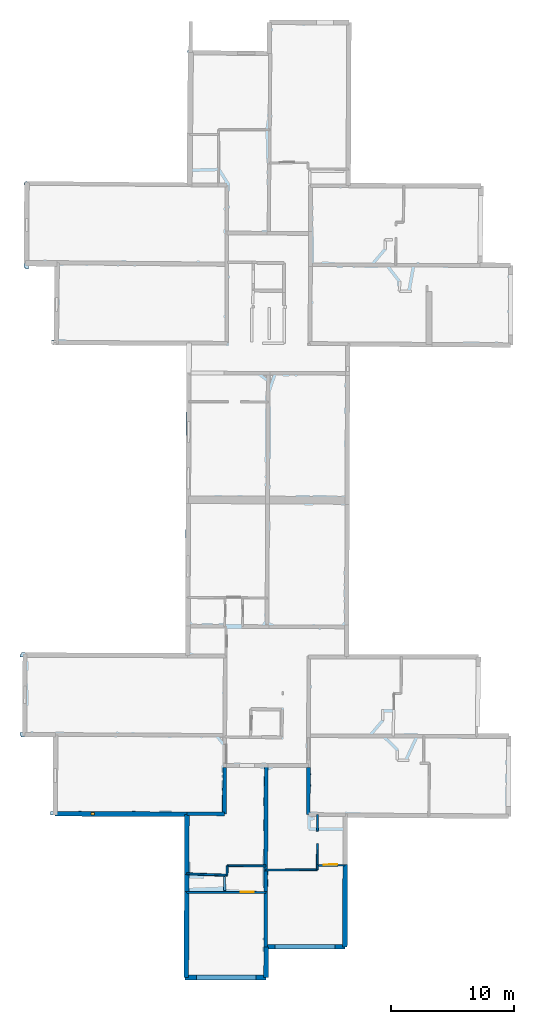
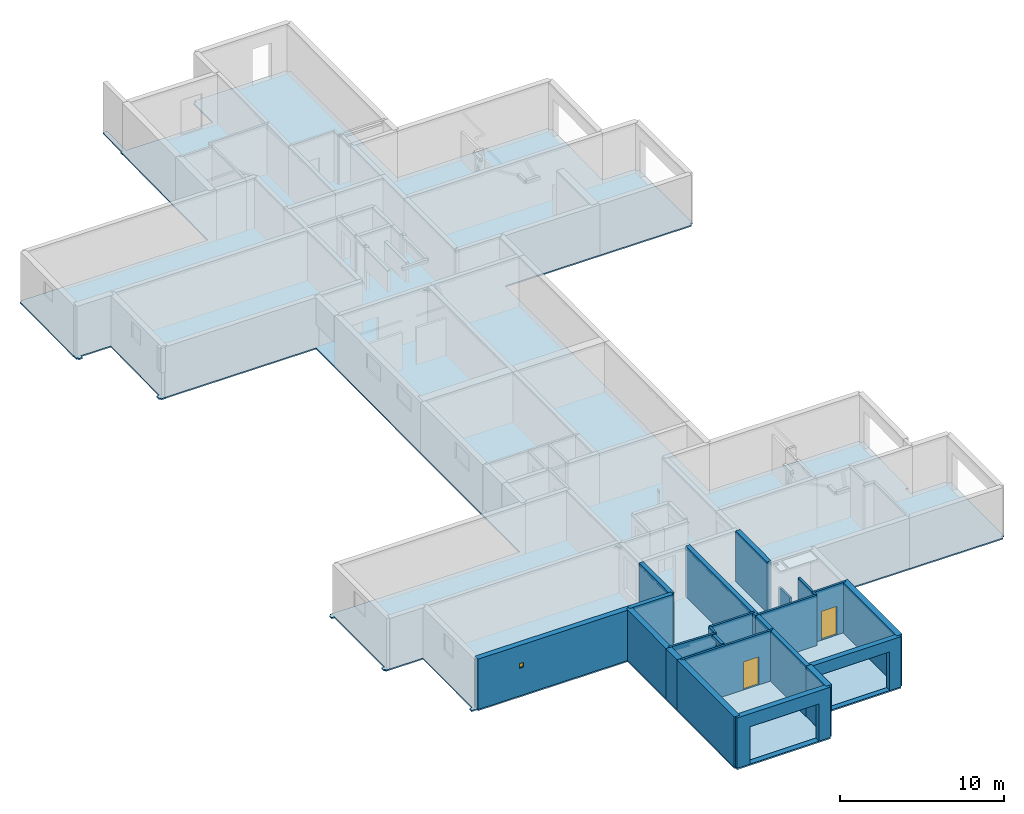
# One storey, part 2 of 12: 24 walls, 2 doors, 1 slab, 1 window, 5 openings.
"""IFC2X3 building model written with IfcOpenShell, lengths in metres."""

from ifc_helpers import new_model, entity, si_unit, converted_unit, derived_unit, direction, frame, frame_2d, origin, origin_2d_with_axis, place, context, subcontext, project, spatial, polyline, rectangle, outline, extrude, source, transform, mapped, material, layer, layer_set, layer_usage, type_object, type_shapes, element, fill, save


model = new_model("IFC2X3")

# Units and contexts
model_context = context("Model", 3, precision=1e-05, world=origin(), true_north=direction((0.0, 1.0)))
body_context = subcontext(model_context, "Body", "Model", "MODEL_VIEW")
ifc_project = project(units=[si_unit("LENGTHUNIT", "METRE"), si_unit("AREAUNIT", "SQUARE_METRE"), si_unit("VOLUMEUNIT", "CUBIC_METRE"), converted_unit("PLANEANGLEUNIT", "DEGREE", entity("IfcRatioMeasure", 0.0174532925199433), si_unit("PLANEANGLEUNIT", "RADIAN"), dimensions=[0, 0, 0, 0, 0, 0, 0]), si_unit("MASSUNIT", "GRAM", prefix="KILO"), derived_unit("MASSDENSITYUNIT", [(si_unit("MASSUNIT", "GRAM", prefix="KILO"), 1), (si_unit("LENGTHUNIT", "METRE"), -3)]), derived_unit("MOMENTOFINERTIAUNIT", [(si_unit("LENGTHUNIT", "METRE"), 4)]), si_unit("TIMEUNIT", "SECOND"), si_unit("FREQUENCYUNIT", "HERTZ"), si_unit("THERMODYNAMICTEMPERATUREUNIT", "DEGREE_CELSIUS"), derived_unit("THERMALTRANSMITTANCEUNIT", [(si_unit("MASSUNIT", "GRAM", prefix="KILO"), 1), (si_unit("THERMODYNAMICTEMPERATUREUNIT", "KELVIN"), -1), (si_unit("TIMEUNIT", "SECOND"), -3)]), derived_unit("VOLUMETRICFLOWRATEUNIT", [(si_unit("LENGTHUNIT", "METRE"), 3), (si_unit("TIMEUNIT", "SECOND"), -1)]), si_unit("ELECTRICCURRENTUNIT", "AMPERE"), si_unit("ELECTRICVOLTAGEUNIT", "VOLT"), si_unit("POWERUNIT", "WATT"), si_unit("FORCEUNIT", "NEWTON", prefix="KILO"), si_unit("ILLUMINANCEUNIT", "LUX"), si_unit("LUMINOUSFLUXUNIT", "LUMEN"), si_unit("LUMINOUSINTENSITYUNIT", "CANDELA"), derived_unit("USERDEFINED", [(si_unit("MASSUNIT", "GRAM", prefix="KILO"), -1), (si_unit("LENGTHUNIT", "METRE"), -2), (si_unit("TIMEUNIT", "SECOND"), 3), (si_unit("LUMINOUSFLUXUNIT", "LUMEN"), 1)]), derived_unit("LINEARVELOCITYUNIT", [(si_unit("LENGTHUNIT", "METRE"), 1), (si_unit("TIMEUNIT", "SECOND"), -1)]), si_unit("PRESSUREUNIT", "PASCAL"), derived_unit("USERDEFINED", [(si_unit("LENGTHUNIT", "METRE"), -2), (si_unit("MASSUNIT", "GRAM", prefix="KILO"), 1), (si_unit("TIMEUNIT", "SECOND"), -2)]), derived_unit("LINEARFORCEUNIT", [(si_unit("MASSUNIT", "GRAM", prefix="KILO"), 1), (si_unit("LENGTHUNIT", "METRE"), 1), (si_unit("TIMEUNIT", "SECOND"), -2), (si_unit("LENGTHUNIT", "METRE"), -1)]), derived_unit("PLANARFORCEUNIT", [(si_unit("MASSUNIT", "GRAM", prefix="KILO"), 1), (si_unit("LENGTHUNIT", "METRE"), 1), (si_unit("TIMEUNIT", "SECOND"), -2), (si_unit("LENGTHUNIT", "METRE"), -2)])], contexts=[model_context])

# Site, building, storey
placement_1 = place(None, origin())
site = spatial("IfcSite", under=ifc_project, at=placement_1, CompositionType="ELEMENT")
building = spatial("IfcBuilding", under=site, at=placement_1, CompositionType="ELEMENT")
storey_placement = place(placement_1, frame((0.0, 0.0, -1.46125340461731)))
storey = spatial("IfcBuildingStorey", under=building, at=storey_placement, Name="Level 1", CompositionType="ELEMENT", Elevation=-1.46125340461731)

# Slab
ifc_material_1 = material(Name="Floor default")
ifc_layer_1 = layer(ifc_material_1, 0.1)
ifc_layer_set_1 = layer_set([ifc_layer_1], Name="Floor : 100mm")
ifc_layer_usage_1 = layer_usage(ifc_layer_set_1, "AXIS3", "POSITIVE", 0.0)
slab_type = type_object("IfcSlabType", Name="Floor : 100mm", PredefinedType="FLOOR")
slab_placement = place(storey_placement, origin())
element("IfcSlab", 1, at=slab_placement, inside=storey, type_object=slab_type, material=ifc_layer_usage_1, Name="Floor : 100mm", ObjectType="Floor : 100mm", PredefinedType="FLOOR", context=body_context, shape_type="SweptSolid", body=[
    extrude(outline(polyline([(-13.8050918579102, 19.4062767028809), (-13.7050933837891, 19.4059658050537), (-13.7059049606323, 19.3059692382812), (-11.1112823486328, 19.2919216156006), (-11.1374282836914, 13.2565183639526), (-11.3285684585571, 13.2569856643677), (-11.3292093276978, 12.9950122833252), (-10.9485664367676, 12.9931516647339), (-10.9491415023804, 12.8931550979614), (-10.9490404129028, 12.8931541442871), (-10.9490728378296, 12.8860168457031), (-0.453227996826172, 12.8384008407593), (-0.501870155334473, -0.211009234189987), (-0.406791687011719, -0.211363643407822), (-0.406643867492676, -0.406788140535355), (6.15542793273926, -0.401811569929123), (6.15528106689453, -0.206812277436256), (6.35027313232422, -0.208174586296082), (6.36635208129883, 2.09300184249878), (12.5501670837402, 2.09511518478394), (12.5501041412354, 2.28011417388916), (12.7401027679443, 2.27959060668945), (12.7689933776855, 12.7631397247314), (25.8164749145508, 12.6806192398071), (25.8176765441895, 12.8706140518188), (26.0076751708984, 12.8698501586914), (26.0338668823242, 19.3831748962402), (25.843864440918, 19.383939743042), (25.8450317382812, 19.5839385986328), (23.3288154602051, 19.5986061096191), (23.3358383178711, 20.1520118713379), (23.4983253479004, 20.1498012542725), (23.5751304626465, 25.793176651001), (23.3901443481445, 25.7956943511963), (23.3905830383301, 25.9806957244873), (12.8717498779297, 26.0055198669434), (12.9627532958984, 50.9822540283203), (25.9994468688965, 50.9114799499512), (26.0004501342773, 51.0964736938477), (26.1854515075684, 51.0964660644531), (26.1857070922852, 57.5692939758301), (26.0007095336914, 57.5693016052246), (26.0022735595703, 57.7642936706543), (23.7047004699707, 57.7827224731445), (23.7827033996582, 63.9966011047363), (23.5927200317383, 63.9989814758301), (23.5935592651367, 64.1889801025391), (13.0179443359375, 64.2356872558594), (13.0707778930664, 77.2585067749023), (12.8807792663574, 77.25927734375), (12.8812522888184, 77.4492797851562), (6.42430686950684, 77.4653778076172), (6.4238338470459, 77.2753829956055), (6.23883628845215, 77.2762298583984), (6.22806167602539, 74.9275283813477), (0.179482460021973, 74.998046875), (0.205533027648926, 77.3357849121094), (-0.0944480895996094, 77.3391265869141), (-0.120400428771973, 75.0102233886719), (-0.19886589050293, 75.010612487793), (-0.199803352355957, 74.8217926025391), (-0.176314353942871, 74.8216781616211), (-0.277120590209961, 64.2619552612305), (-13.2495880126953, 64.3790740966797), (-13.2497205734253, 64.3644027709961), (-13.3700389862061, 64.3652191162109), (-13.370719909668, 64.2651748657227), (-13.4507398605347, 64.2656860351562), (-13.4507427215576, 64.2651596069336), (-13.4707202911377, 64.2651443481445), (-13.470573425293, 64.0771713256836), (-13.4519424438477, 64.0771865844727), (-13.4924249649048, 57.7337074279785), (-13.4655990600586, 57.7335357666016), (-13.4653291702271, 57.386890411377), (-13.3653297424316, 57.3869667053223), (-13.3654556274414, 57.2869644165039), (-13.1122999191284, 57.2866477966309), (-13.1120376586914, 57.4958114624023), (-11.0008916854858, 57.4770469665527), (-11.0611953735352, 51.4972648620605), (-11.2529039382935, 51.4983863830566), (-11.2547340393066, 51.1863746643066), (-11.1547365188599, 51.185791015625), (-11.1549625396729, 51.0857925415039), (-10.8695583343506, 51.0851516723633), (-10.8695135116577, 51.1048965454102), (-0.296536445617676, 51.0481338500977), (-0.383402824401855, 30.6201953887939), (-0.375576972961426, 30.6201572418213), (-0.377828598022461, 28.7561988830566), (-0.365597724914551, 28.7561836242676), (-0.388607978820801, 26.1072330474854), (-13.3999700546265, 26.149658203125), (-13.3999557495117, 26.1539554595947), (-13.6841106414795, 26.1549129486084), (-13.6844472885132, 26.0549144744873), (-13.7844476699829, 26.0552253723145), (-13.7852792739868, 25.7872772216797), (-13.5810680389404, 25.786642074585), (-13.5988216400146, 19.6666679382324), (-13.8042812347412, 19.6673069000244), (-13.8050918579102, 19.4062767028809), (-13.8050918579102, 19.4062767028809), (-13.8050918579102, 19.4062767028809)])), frame((0.0, 0.0, -0.1), z_axis=(0.0, 0.0, 1.0), x_axis=(1.0, 0.0, 0.0)), (0.0, 0.0, 1.0), 0.1),
])

# Walls
ifc_material_2 = material(Name="Default wall")
ifc_layer_2 = layer(ifc_material_2, 0.2)
ifc_layer_set_2 = layer_set([ifc_layer_2], Name="wall_thickness_0.2000")
ifc_layer_usage_2 = layer_usage(ifc_layer_set_2, "AXIS2", "POSITIVE", -0.1)
wall_type_1 = type_object("IfcWallType", Name="wall_thickness_0.2000", PredefinedType="STANDARD", material=ifc_layer_set_2)
placement_2 = place(placement_1, frame((0.0, 0.0, 2.04199981689453)))
wall_1_placement = place(placement_2, frame((2.78647715415137, 6.86913500337074, 0.0), z_axis=(0.0, 0.0, 1.0), x_axis=(-0.00357050619963252, 0.999993625722423, 0.0)))
element("IfcWallStandardCase", 2, at=wall_1_placement, inside=storey, type_object=wall_type_1, material=ifc_layer_usage_2, Name="Wall:585", ObjectType="Wall", context=body_context, shape_type="SweptSolid", body=[
    extrude(outline(polyline([(1.11499972587854, -0.1), (1.11499972587854, 0.1), (0.0, 0.1), (0.0, -0.1), (1.11499972587854, -0.1)])), origin(), (0.0, 0.0, 1.0), 0.238732957839966),
])
ifc_layer_3 = layer(ifc_material_2, 0.379999995231628)
ifc_layer_set_3 = layer_set([ifc_layer_3], Name="wall_thickness_0.3800")
ifc_layer_usage_3 = layer_usage(ifc_layer_set_3, "AXIS2", "POSITIVE", -0.189999997615814)
wall_type_2 = type_object("IfcWallType", Name="wall_thickness_0.3800", PredefinedType="STANDARD", material=ifc_layer_set_3)
wall_2_placement = place(storey_placement, frame((-0.262502601984851, 13.0325380702062, 0.0), z_axis=(0.0, 0.0, 1.0), x_axis=(-0.00372755911150731, -0.999993052627402, 0.0)))
element("IfcWallStandardCase", 3, at=wall_2_placement, inside=storey, type_object=wall_type_2, material=ifc_layer_usage_3, Name="Wall:539", ObjectType="Wall", context=body_context, shape_type="SweptSolid", body=[
    extrude(outline(polyline([(4.89215053422343, -0.189999997615814), (4.89215053422343, 0.189999997615814), (0.0, 0.189999997615814), (0.0, -0.189999997615814), (4.89215053422343, -0.189999997615814)])), origin(), (0.0, 0.0, 1.0), 3.74198617935181),
])
wall_3_placement = place(storey_placement, frame((-0.280738382283561, 8.14042152357538, 0.0), z_axis=(0.0, 0.0, 1.0), x_axis=(-0.00372756162688016, -0.999993052618026, 0.0)))
element("IfcWallStandardCase", 4, at=wall_3_placement, inside=storey, type_object=wall_type_2, material=ifc_layer_usage_3, Name="Wall:540", ObjectType="Wall", context=body_context, shape_type="SweptSolid", body=[
    extrude(outline(polyline([(1.36028662633411, -0.189999997615814), (1.36028662633411, 0.189999997615814), (0.0, 0.189999997615814), (0.0, -0.189999997615814), (1.36028662633411, -0.189999997615814)])), origin(), (0.0, 0.0, 1.0), 3.74198617935181),
])
wall_4_placement = place(storey_placement, frame((-0.285808934513442, 6.78014434767206, 0.0), z_axis=(0.0, 0.0, 1.0), x_axis=(-0.00372755981592958, -0.999993052624776, 0.0)))
element("IfcWallStandardCase", 5, at=wall_4_placement, inside=storey, type_object=wall_type_2, material=ifc_layer_usage_3, Name="Wall:541", ObjectType="Wall", context=body_context, shape_type="SweptSolid", body=[
    extrude(outline(polyline([(6.991910395646, -0.189999997615814), (6.991910395646, 0.189999997615814), (0.0, 0.189999997615814), (0.0, -0.189999997615814), (6.991910395646, -0.189999997615814)])), origin(), (0.0, 0.0, 1.0), 3.74198617935181),
])
wall_5_placement = place(storey_placement, frame((12.5685551823294, 8.97581384766353, 0.0), z_axis=(0.0, 0.0, 1.0), x_axis=(-0.00275574196289732, -0.999996202935908, 0.0)))
element("IfcWallStandardCase", 6, at=wall_5_placement, inside=storey, type_object=wall_type_2, material=ifc_layer_usage_3, Name="Wall:576", ObjectType="Wall", context=body_context, shape_type="SweptSolid", body=[
    extrude(outline(polyline([(6.69572511586987, -0.189999997615814), (6.69572511586987, 0.189999997615814), (0.0, 0.189999997615814), (0.0, -0.189999997615814), (6.69572511586987, -0.189999997615814)])), origin(), (0.0, 0.0, 1.0), 3.74198617935181),
])

# Wall, opening
ifc_layer_4 = layer(ifc_material_2, 0.370000004768372)
ifc_layer_set_4 = layer_set([ifc_layer_4], Name="wall_thickness_0.3700")
ifc_layer_usage_4 = layer_usage(ifc_layer_set_4, "AXIS2", "POSITIVE", -0.185000002384186)
wall_type_3 = type_object("IfcWallType", Name="wall_thickness_0.3700", PredefinedType="STANDARD", material=ifc_layer_set_4)
wall_6_placement = place(storey_placement, frame((6.11794683574739, 2.27791695707071, 0.0), z_axis=(0.0, 0.0, 1.0), x_axis=(0.9999999416019, 0.000341754586742305, 0.0)))
wall_6 = element("IfcWallStandardCase", 7, at=wall_6_placement, inside=storey, type_object=wall_type_3, material=ifc_layer_usage_4, Name="Wall:565", ObjectType="Wall", context=body_context, shape_type="SweptSolid", body=[
    extrude(outline(polyline([(6.43215741526811, -0.185000002384186), (6.43215741526811, 0.185000002384186), (0.0, 0.185000002384186), (0.0, -0.185000002384186), (6.43215741526811, -0.185000002384186)])), origin(), (0.0, 0.0, 1.0), 3.74198617935181),
])
opening_1_placement = place(wall_6_placement, frame((0.768599538850936, -0.185000002384186, 0.00725388526916504)))
element("IfcOpeningElement", 8, at=opening_1_placement, cuts=wall_6, Name="Opening : 4865 x 2875 : 412", ObjectType="Opening", context=body_context, shape_type="SweptSolid", body=[
    extrude(rectangle(XDim=4.865, YDim=2.875, at=frame_2d((1.4375, 2.4325), x_axis=(0.0, 1.0))), frame((0.0, 0.0, 0.0), z_axis=(0.0, 1.0, 0.0), x_axis=(0.0, 0.0, 1.0)), (0.0, 0.0, 1.0), 0.370000004768372),
])

ifc_layer_5 = layer(ifc_material_2, 0.389999985694885)
ifc_layer_set_5 = layer_set([ifc_layer_5], Name="wall_thickness_0.3900")
ifc_layer_usage_5 = layer_usage(ifc_layer_set_5, "AXIS2", "POSITIVE", -0.194999992847443)
wall_type_4 = type_object("IfcWallType", Name="wall_thickness_0.3900", PredefinedType="STANDARD", material=ifc_layer_set_5)
wall_7_placement = place(storey_placement, frame((-0.406791752213433, -0.211788203764565, 0.0), z_axis=(0.0, 0.0, 1.0), x_axis=(0.99999971242698, 0.000758383779540905, 0.0)))
wall_7 = element("IfcWallStandardCase", 9, at=wall_7_placement, inside=storey, type_object=wall_type_4, material=ifc_layer_usage_5, Name="Wall:612", ObjectType="Wall", context=body_context, shape_type="SweptSolid", body=[
    extrude(outline(polyline([(6.56207416414458, -0.194999992847443), (6.56207416414458, 0.194999992847443), (0.0, 0.194999992847443), (0.0, -0.194999992847443), (6.56207416414458, -0.194999992847443)])), origin(), (0.0, 0.0, 1.0), 3.74198617935181),
])
opening_2_placement = place(wall_7_placement, frame((0.910432838817723, -0.194999992847443, 0.00625348091125488)))
element("IfcOpeningElement", 10, at=opening_2_placement, cuts=wall_7, Name="Opening : 4850 x 2770 : 421", ObjectType="Opening", context=body_context, shape_type="SweptSolid", body=[
    extrude(rectangle(XDim=4.85, YDim=2.77, at=frame_2d((1.385, 2.425), x_axis=(0.0, 1.0))), frame((0.0, 0.0, 0.0), z_axis=(0.0, 1.0, 0.0), x_axis=(0.0, 0.0, 1.0)), (0.0, 0.0, 1.0), 0.389999985694885),
])

# Wall
wall_8_placement = place(storey_placement, frame((6.17263953927485, 2.27793693899726, 0.0), z_axis=(0.0, 0.0, 1.0), x_axis=(-0.006986726684372, -0.999975592527257, 0.0)))
element("IfcWallStandardCase", 11, at=wall_8_placement, inside=storey, type_object=wall_type_4, material=ifc_layer_usage_5, Name="Wall:666", ObjectType="Wall", context=body_context, shape_type="SweptSolid", body=[
    extrude(outline(polyline([(2.48480984588849, -0.194999992847443), (2.48480984588849, 0.194999992847443), (0.0, 0.194999992847443), (0.0, -0.194999992847443), (2.48480984588849, -0.194999992847443)])), origin(), (0.0, 0.0, 1.0), 3.74198617935181),
])

# Wall, opening, window
wall_9_placement = place(storey_placement, frame((-10.9481883897181, 13.081014434352, 0.0), z_axis=(0.0, 0.0, 1.0), x_axis=(0.999989709582273, -0.00453659889803798, 0.0)))
wall_9 = element("IfcWallStandardCase", 12, at=wall_9_placement, inside=storey, type_object=wall_type_4, material=ifc_layer_usage_5, Name="Wall:684", ObjectType="Wall", context=body_context, shape_type="SweptSolid", body=[
    extrude(outline(polyline([(10.6857965495976, -0.194999992847443), (10.6857965495976, 0.194999992847443), (0.0, 0.194999992847443), (0.0, -0.194999992847443), (10.6857965495976, -0.194999992847443)])), origin(), (0.0, 0.0, 1.0), 3.74198617935181),
])
opening_3_placement = place(wall_9_placement, frame((2.89561579035191, -0.194999992847443, 2.04825365543365)))
opening_3 = element("IfcOpeningElement", 13, at=opening_3_placement, cuts=wall_9, Name="Opening : 310 x 345 : 432", ObjectType="Opening", context=body_context, shape_type="SweptSolid", body=[
    extrude(rectangle(XDim=0.31, YDim=0.345, at=frame_2d((0.1725, 0.155), x_axis=(0.0, 1.0))), frame((0.0, 0.0, 0.0), z_axis=(0.0, 1.0, 0.0), x_axis=(0.0, 0.0, 1.0)), (0.0, 0.0, 1.0), 0.389999985694885),
])
ifc_material_3 = material(Name="Window Default")
window_style = type_object("IfcWindowStyle", Name="Window : 310 x 345mm", ConstructionType="NOTDEFINED", OperationType="NOTDEFINED", ParameterTakesPrecedence=False, Sizeable=False, material=ifc_material_3)
shared_shape_1 = source(origin(), body_context, "Body", "SweptSolid", [
    extrude(rectangle(XDim=0.194999992847443, YDim=0.31, at=origin_2d_with_axis()), frame((0.155, 0.194999992847443, 0.0), z_axis=(0.0, 0.0, 1.0), x_axis=(0.0, 1.0, 0.0)), (0.0, 0.0, 1.0), 0.345),
])
type_shapes(window_style, [shared_shape_1])
window_placement = place(opening_3_placement, origin())
window = element("IfcWindow", 14, at=window_placement, inside=storey, type_object=window_style, Name="Window : 310 x 345mm : 235", ObjectType="Window : 310 x 345mm", OverallHeight=0.345, OverallWidth=0.31, context=body_context, shape_type="MappedRepresentation", body=[
    mapped(shared_shape_1, transform((0.0, 0.0, 0.0), scale=1.0)),
])
fill(opening_3, window)

# Wall, opening, door
ifc_layer_6 = layer(ifc_material_2, 0.150000005960464)
ifc_layer_set_6 = layer_set([ifc_layer_6], Name="wall_thickness_0.1500")
ifc_layer_usage_6 = layer_usage(ifc_layer_set_6, "AXIS2", "POSITIVE", -0.0750000029802322)
wall_type_5 = type_object("IfcWallType", Name="wall_thickness_0.1500", PredefinedType="STANDARD", material=ifc_layer_set_6)
wall_10_placement = place(storey_placement, frame((10.3105600977505, 8.87834424356734, 0.0), z_axis=(0.0, 0.0, 1.0), x_axis=(0.999950453066047, 0.00995446698759837, 0.0)))
wall_10 = element("IfcWallStandardCase", 15, at=wall_10_placement, inside=storey, type_object=wall_type_5, material=ifc_layer_usage_6, Name="Wall:518", ObjectType="Wall", context=body_context, shape_type="SweptSolid", body=[
    extrude(outline(polyline([(2.25790053019053, -0.0750000029802322), (2.25790053019053, 0.0750000029802322), (0.0, 0.0750000029802322), (0.0, -0.0750000029802322), (2.25790053019053, -0.0750000029802322)])), origin(), (0.0, 0.0, 1.0), 3.74198617935181),
])
opening_4_placement = place(wall_10_placement, frame((0.514335347532189, -0.0750000029802322, 0.0242540836334229)))
opening_4 = element("IfcOpeningElement", 16, at=opening_4_placement, cuts=wall_10, Name="Opening : 1105 x 2115 : 406", ObjectType="Opening", context=body_context, shape_type="SweptSolid", body=[
    extrude(rectangle(XDim=1.105, YDim=2.115, at=frame_2d((1.0575, 0.5525), x_axis=(0.0, 1.0))), frame((0.0, 0.0, 0.0), z_axis=(0.0, 1.0, 0.0), x_axis=(0.0, 0.0, 1.0)), (0.0, 0.0, 1.0), 0.150000005960464),
])
ifc_material_4 = material(Name="Door Panel")
door_style_1 = type_object("IfcDoorStyle", Name="Door : 1105 x 2115mm", ConstructionType="NOTDEFINED", OperationType="SINGLE_SWING_RIGHT", ParameterTakesPrecedence=False, Sizeable=False, material=ifc_material_4)
shared_shape_2 = source(origin(), body_context, "Body", "SweptSolid", [
    extrude(rectangle(XDim=0.0375000014901161, YDim=1.105, at=origin_2d_with_axis()), frame((0.5525, 0.131250005215406, 0.0), z_axis=(0.0, 0.0, 1.0), x_axis=(0.0, 1.0, 0.0)), (0.0, 0.0, 1.0), 2.115),
])
type_shapes(door_style_1, [shared_shape_2])
door_1_placement = place(opening_4_placement, origin())
door_1 = element("IfcDoor", 17, at=door_1_placement, inside=storey, type_object=door_style_1, Name="Door : 1105 x 2115mm : 74", ObjectType="Door : 1105 x 2115mm", OverallHeight=2.115, OverallWidth=1.105, context=body_context, shape_type="MappedRepresentation", body=[
    mapped(shared_shape_2, transform((0.0, 0.0, 0.0), scale=1.0)),
])
fill(opening_4, door_1)

# Wall
wall_11_placement = place(storey_placement, frame((-0.280458884036371, 8.21538394799027, 0.0), z_axis=(0.0, 0.0, 1.0), x_axis=(0.999379943939341, -0.0352097664263766, 0.0)))
element("IfcWallStandardCase", 18, at=wall_11_placement, inside=storey, type_object=wall_type_5, material=ifc_layer_usage_6, Name="Wall:522", ObjectType="Wall", context=body_context, shape_type="SweptSolid", body=[
    extrude(outline(polyline([(3.27290412273049, -0.0750000029802322), (3.27290412273049, 0.0750000029802322), (0.0, 0.0750000029802322), (0.0, -0.0750000029802322), (3.27290412273049, -0.0750000029802322)])), origin(), (0.0, 0.0, 1.0), 3.74198617935181),
])

# Wall, opening, door
wall_12_placement = place(storey_placement, frame((-0.286088487814669, 6.70514461688378, 0.0), z_axis=(0.0, 0.0, 1.0), x_axis=(0.999994596945127, -0.00328726034162565, 0.0)))
wall_12 = element("IfcWallStandardCase", 19, at=wall_12_placement, inside=storey, type_object=wall_type_5, material=ifc_layer_usage_6, Name="Wall:543", ObjectType="Wall", context=body_context, shape_type="SweptSolid", body=[
    extrude(outline(polyline([(6.41757188686488, -0.0750000029802322), (6.41757188686488, 0.0750000029802322), (0.0, 0.0750000029802322), (0.0, -0.0750000029802322), (6.41757188686488, -0.0750000029802322)])), origin(), (0.0, 0.0, 1.0), 3.74198617935181),
])
opening_5_placement = place(wall_12_placement, frame((4.38533625287541, -0.0750000029802322, 0.00825321674346924)))
opening_5 = element("IfcOpeningElement", 20, at=opening_5_placement, cuts=wall_12, Name="Opening : 1070 x 2070 : 409", ObjectType="Opening", context=body_context, shape_type="SweptSolid", body=[
    extrude(rectangle(XDim=1.07, YDim=2.07, at=frame_2d((1.035, 0.535), x_axis=(0.0, 1.0))), frame((0.0, 0.0, 0.0), z_axis=(0.0, 1.0, 0.0), x_axis=(0.0, 0.0, 1.0)), (0.0, 0.0, 1.0), 0.150000005960464),
])
door_style_2 = type_object("IfcDoorStyle", Name="Door : 1070 x 2070mm", ConstructionType="NOTDEFINED", OperationType="SINGLE_SWING_RIGHT", ParameterTakesPrecedence=False, Sizeable=False, material=ifc_material_4)
shared_shape_3 = source(origin(), body_context, "Body", "SweptSolid", [
    extrude(rectangle(XDim=0.0375000014901161, YDim=1.07, at=origin_2d_with_axis()), frame((0.535, 0.131250005215406, 0.0), z_axis=(0.0, 0.0, 1.0), x_axis=(0.0, 1.0, 0.0)), (0.0, 0.0, 1.0), 2.07),
])
type_shapes(door_style_2, [shared_shape_3])
door_2_placement = place(opening_5_placement, origin())
door_2 = element("IfcDoor", 21, at=door_2_placement, inside=storey, type_object=door_style_2, Name="Door : 1070 x 2070mm : 75", ObjectType="Door : 1070 x 2070mm", OverallHeight=2.07, OverallWidth=1.07, context=body_context, shape_type="MappedRepresentation", body=[
    mapped(shared_shape_3, transform((0.0, 0.0, 0.0), scale=1.0)),
])
fill(opening_5, door_2)

# Walls
wall_13_placement = place(storey_placement, frame((6.13704510983818, 8.51064691442638, 0.0), z_axis=(0.0, 0.0, 1.0), x_axis=(0.999973241894843, 0.00731542851226492, 0.0)))
element("IfcWallStandardCase", 22, at=wall_13_placement, inside=storey, type_object=wall_type_5, material=ifc_layer_usage_6, Name="Wall:574", ObjectType="Wall", context=body_context, shape_type="SweptSolid", body=[
    extrude(outline(polyline([(4.17167334406108, -0.0750000029802322), (4.17167334406108, 0.0750000029802322), (0.0, 0.0750000029802322), (0.0, -0.0750000029802322), (4.17167334406108, -0.0750000029802322)])), origin(), (0.0, 0.0, 1.0), 3.74198617935181),
])
wall_14_placement = place(storey_placement, frame((2.99823807410696, 8.8555094313956, 0.0), z_axis=(0.0, 0.0, 1.0), x_axis=(-0.010354747096505, -0.999946388169169, 0.0)))
element("IfcWallStandardCase", 23, at=wall_14_placement, inside=storey, type_object=wall_type_5, material=ifc_layer_usage_6, Name="Wall:625", ObjectType="Wall", context=body_context, shape_type="SweptSolid", body=[
    extrude(outline(polyline([(0.755405870395834, -0.0750000029802322), (0.755405870395834, 0.0750000029802322), (0.0, 0.0750000029802322), (0.0, -0.0750000029802322), (0.755405870395834, -0.0750000029802322)])), origin(), (0.0, 0.0, 1.0), 3.74198617935181),
])
wall_15_placement = place(storey_placement, frame((2.99823768770271, 8.85551184445282, 0.0), z_axis=(0.0, 0.0, 1.0), x_axis=(0.999999805017251, -0.000624472144501992, 0.0)))
element("IfcWallStandardCase", 24, at=wall_15_placement, inside=storey, type_object=wall_type_5, material=ifc_layer_usage_6, Name="Wall:644", ObjectType="Wall", context=body_context, shape_type="SweptSolid", body=[
    extrude(outline(polyline([(3.13985885806792, -0.0750000029802322), (3.13985885806792, 0.0750000029802322), (0.0, 0.0750000029802322), (0.0, -0.0750000029802322), (3.13985885806792, -0.0750000029802322)])), origin(), (0.0, 0.0, 1.0), 3.74198617935181),
])
wall_16_placement = place(storey_placement, frame((10.3299766771482, 13.0137711610084, 0.0), z_axis=(0.0, 0.0, 1.0), x_axis=(-0.00681682642719486, -0.999976765168802, 0.0)))
element("IfcWallStandardCase", 25, at=wall_16_placement, inside=storey, type_object=wall_type_5, material=ifc_layer_usage_6, Name="Wall:662", ObjectType="Wall", context=body_context, shape_type="SweptSolid", body=[
    extrude(outline(polyline([(1.34178132102099, -0.0750000029802322), (1.34178132102099, 0.0750000029802322), (0.0, 0.0750000029802322), (0.0, -0.0750000029802322), (1.34178132102099, -0.0750000029802322)])), origin(), (0.0, 0.0, 1.0), 1.60625338554382),
])
ifc_layer_7 = layer(ifc_material_2, 0.140000000596046)
ifc_layer_set_7 = layer_set([ifc_layer_7], Name="wall_thickness_0.1400")
ifc_layer_usage_7 = layer_usage(ifc_layer_set_7, "AXIS2", "POSITIVE", -0.0700000002980232)
wall_type_6 = type_object("IfcWallType", Name="wall_thickness_0.1400", PredefinedType="STANDARD", material=ifc_layer_set_7)
wall_17_placement = place(storey_placement, frame((10.3208199388813, 10.6488883147009, 0.0), z_axis=(0.0, 0.0, 1.0), x_axis=(-0.00579432069313091, -0.999983212782947, 0.0)))
element("IfcWallStandardCase", 26, at=wall_17_placement, inside=storey, type_object=wall_type_6, material=ifc_layer_usage_7, Name="Wall:557", ObjectType="Wall", context=body_context, shape_type="SweptSolid", body=[
    extrude(outline(polyline([(1.69558319739953, -0.0700000002980232), (1.69558319739953, 0.0700000002980232), (0.0, 0.0700000002980232), (0.0, -0.0700000002980232), (1.69558319739953, -0.0700000002980232)])), origin(), (0.0, 0.0, 1.0), 3.74198617935181),
])
wall_18_placement = place(storey_placement, frame((10.3109951860737, 8.9533335814245, 0.0), z_axis=(0.0, 0.0, 1.0), x_axis=(-0.0057936240719757, -0.999983216819219, 0.0)))
element("IfcWallStandardCase", 27, at=wall_18_placement, inside=storey, type_object=wall_type_6, material=ifc_layer_usage_7, Name="Wall:558", ObjectType="Wall", context=body_context, shape_type="SweptSolid", body=[
    extrude(outline(polyline([(0.412177327802856, -0.0700000002980232), (0.412177327802856, 0.0700000002980232), (0.0, 0.0700000002980232), (0.0, -0.0700000002980232), (0.412177327802856, -0.0700000002980232)])), origin(), (0.0, 0.0, 1.0), 3.74198617935181),
])
ifc_layer_8 = layer(ifc_material_2, 0.300000011920929)
ifc_layer_set_8 = layer_set([ifc_layer_8], Name="wall_thickness_0.3000")
ifc_layer_usage_8 = layer_usage(ifc_layer_set_8, "AXIS2", "POSITIVE", -0.150000005960464)
wall_type_7 = type_object("IfcWallType", Name="wall_thickness_0.3000", PredefinedType="STANDARD", material=ifc_layer_set_8)
wall_19_placement = place(storey_placement, frame((6.16303523271038, 16.9920825599433, 0.0), z_axis=(0.0, 0.0, 1.0), x_axis=(-0.0030642178514731, -0.999995305273459, 0.0)))
element("IfcWallStandardCase", 28, at=wall_19_placement, inside=storey, type_object=wall_type_7, material=ifc_layer_usage_8, Name="Wall:506", ObjectType="Wall", context=body_context, shape_type="SweptSolid", body=[
    extrude(outline(polyline([(8.55647098694183, -0.150000005960464), (8.55647098694183, 0.150000005960464), (0.0, 0.150000005960464), (0.0, -0.150000005960464), (8.55647098694183, -0.150000005960464)])), origin(), (0.0, 0.0, 1.0), 3.74198617935181),
])
wall_20_placement = place(storey_placement, frame((6.13681634156658, 8.4356517432929, 0.0), z_axis=(0.0, 0.0, 1.0), x_axis=(-0.00306418128190644, -0.999995305385516, 0.0)))
element("IfcWallStandardCase", 29, at=wall_20_placement, inside=storey, type_object=wall_type_7, material=ifc_layer_usage_8, Name="Wall:507", ObjectType="Wall", context=body_context, shape_type="SweptSolid", body=[
    extrude(outline(polyline([(1.6766121419827, -0.150000005960464), (1.6766121419827, 0.150000005960464), (0.0, 0.150000005960464), (0.0, -0.150000005960464), (1.6766121419827, -0.150000005960464)])), origin(), (0.0, 0.0, 1.0), 3.74198617935181),
])
wall_21_placement = place(storey_placement, frame((6.1316788980241, 6.75904747235784, 0.0), z_axis=(0.0, 0.0, 1.0), x_axis=(-0.00306427405945806, -0.999995305101223, 0.0)))
element("IfcWallStandardCase", 30, at=wall_21_placement, inside=storey, type_object=wall_type_7, material=ifc_layer_usage_8, Name="Wall:508", ObjectType="Wall", context=body_context, shape_type="SweptSolid", body=[
    extrude(outline(polyline([(4.48115259220773, -0.150000005960464), (4.48115259220773, 0.150000005960464), (0.0, 0.150000005960464), (0.0, -0.150000005960464), (4.48115259220773, -0.150000005960464)])), origin(), (0.0, 0.0, 1.0), 3.74198617935181),
])
wall_22_placement = place(storey_placement, frame((2.79876669678978, 16.8336616469798, 0.0), z_axis=(0.0, 0.0, 1.0), x_axis=(-0.00446579174148642, -0.999990028302344, 0.0)))
element("IfcWallStandardCase", 31, at=wall_22_placement, inside=storey, type_object=wall_type_7, material=ifc_layer_usage_8, Name="Wall:660", ObjectType="Wall", context=body_context, shape_type="SweptSolid", body=[
    extrude(outline(polyline([(3.76997606199457, -0.150000005960464), (3.76997606199457, 0.150000005960464), (0.0, 0.150000005960464), (0.0, -0.150000005960464), (3.76997606199457, -0.150000005960464)])), origin(), (0.0, 0.0, 1.0), 3.74198617935181),
])
wall_23_placement = place(storey_placement, frame((-0.262334971224228, 13.0775386926863, 0.0), z_axis=(0.0, 0.0, 1.0), x_axis=(0.999989706208964, -0.00453734240609535, 0.0)))
element("IfcWallStandardCase", 32, at=wall_23_placement, inside=storey, type_object=wall_type_7, material=ifc_layer_usage_8, Name="Wall:685", ObjectType="Wall", context=body_context, shape_type="SweptSolid", body=[
    extrude(outline(polyline([(3.04429720363887, -0.150000005960464), (3.04429720363887, 0.150000005960464), (0.0, 0.150000005960464), (0.0, -0.150000005960464), (3.04429720363887, -0.150000005960464)])), origin(), (0.0, 0.0, 1.0), 3.74198617935181),
])
ifc_layer_9 = layer(ifc_material_2, 0.310000002384186)
ifc_layer_set_9 = layer_set([ifc_layer_9], Name="wall_thickness_0.3100")
ifc_layer_usage_9 = layer_usage(ifc_layer_set_9, "AXIS2", "POSITIVE", -0.155000001192093)
wall_type_8 = type_object("IfcWallType", Name="wall_thickness_0.3100", PredefinedType="STANDARD", material=ifc_layer_set_9)
wall_24_placement = place(storey_placement, frame((9.59155153251102, 16.8405762622173, 0.0), z_axis=(0.0, 0.0, 1.0), x_axis=(-0.00354487350144728, -0.999993716916191, 0.0)))
element("IfcWallStandardCase", 33, at=wall_24_placement, inside=storey, type_object=wall_type_8, material=ifc_layer_usage_9, Name="Wall:621", ObjectType="Wall", context=body_context, shape_type="SweptSolid", body=[
    extrude(outline(polyline([(3.82155912164988, -0.155000001192093), (3.82155912164988, 0.155000001192093), (0.0, 0.155000001192093), (0.0, -0.155000001192093), (3.82155912164988, -0.155000001192093)])), origin(), (0.0, 0.0, 1.0), 3.74198617935181),
])

save(model, "model.ifc")
